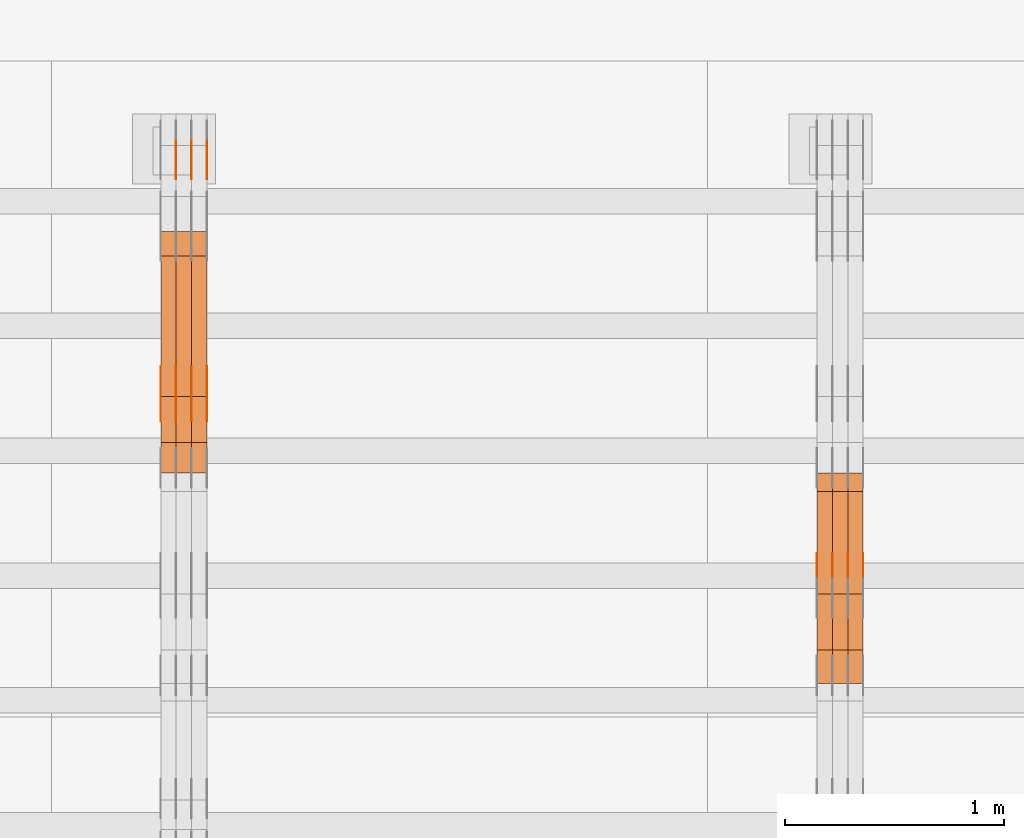
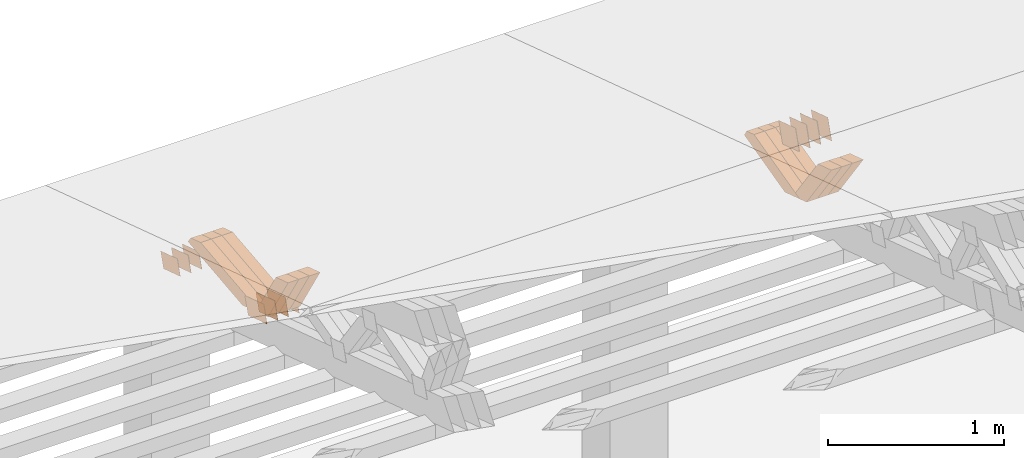
# One storey, part 237 of 385: 28 proxies.
"""IFC2X3 building model written with IfcOpenShell, lengths in millimetres."""

from ifc_helpers import new_model, entity, si_unit, converted_unit, derived_unit, direction, frame, origin, place, context, subcontext, project, spatial, polyline, outline, extrude, source, transform, mapped, material, type_object, type_shapes, element, save


model = new_model("IFC2X3")

# Units and contexts
model_context = context("Model", 3, precision=0.01, world=origin(), true_north=direction((6.12303176911189e-17, 1.0)))
body_context = subcontext(model_context, "Body", "Model", "MODEL_VIEW")
ifc_project = project(units=[si_unit("LENGTHUNIT", "METRE", prefix="MILLI"), si_unit("AREAUNIT", "SQUARE_METRE"), si_unit("VOLUMEUNIT", "CUBIC_METRE"), converted_unit("PLANEANGLEUNIT", "DEGREE", entity("IfcRatioMeasure", 0.0174532925199433), si_unit("PLANEANGLEUNIT", "RADIAN"), dimensions=[0, 0, 0, 0, 0, 0, 0]), si_unit("MASSUNIT", "GRAM", prefix="KILO"), derived_unit("MASSDENSITYUNIT", [(si_unit("MASSUNIT", "GRAM", prefix="KILO"), 1), (si_unit("LENGTHUNIT", "METRE"), -3)]), si_unit("TIMEUNIT", "SECOND"), si_unit("FREQUENCYUNIT", "HERTZ"), si_unit("THERMODYNAMICTEMPERATUREUNIT", "DEGREE_CELSIUS"), derived_unit("THERMALTRANSMITTANCEUNIT", [(si_unit("MASSUNIT", "GRAM", prefix="KILO"), 1), (si_unit("THERMODYNAMICTEMPERATUREUNIT", "KELVIN"), -1), (si_unit("TIMEUNIT", "SECOND"), -3)]), derived_unit("VOLUMETRICFLOWRATEUNIT", [(si_unit("LENGTHUNIT", "METRE"), 3), (si_unit("TIMEUNIT", "SECOND"), -1)]), si_unit("ELECTRICCURRENTUNIT", "AMPERE"), si_unit("ELECTRICVOLTAGEUNIT", "VOLT"), si_unit("POWERUNIT", "WATT"), si_unit("FORCEUNIT", "NEWTON", prefix="KILO"), si_unit("ILLUMINANCEUNIT", "LUX"), si_unit("LUMINOUSFLUXUNIT", "LUMEN"), si_unit("LUMINOUSINTENSITYUNIT", "CANDELA"), derived_unit("USERDEFINED", [(si_unit("MASSUNIT", "GRAM", prefix="KILO"), -1), (si_unit("LENGTHUNIT", "METRE"), -2), (si_unit("TIMEUNIT", "SECOND"), 3), (si_unit("LUMINOUSFLUXUNIT", "LUMEN"), 1)]), derived_unit("LINEARVELOCITYUNIT", [(si_unit("LENGTHUNIT", "METRE"), 1), (si_unit("TIMEUNIT", "SECOND"), -1)]), si_unit("PRESSUREUNIT", "PASCAL"), derived_unit("USERDEFINED", [(si_unit("LENGTHUNIT", "METRE"), -2), (si_unit("MASSUNIT", "GRAM", prefix="KILO"), 1), (si_unit("TIMEUNIT", "SECOND"), -2)])], contexts=[model_context])

# Site, building, storey
site_placement = place(None, origin())
site = spatial("IfcSite", under=ifc_project, at=site_placement, CompositionType="ELEMENT")
building_placement = place(site_placement, origin())
building = spatial("IfcBuilding", under=site, at=building_placement, CompositionType="ELEMENT")
storey_placement = place(building_placement, origin())
storey = spatial("IfcBuildingStorey", under=building, at=storey_placement, Name="Default", CompositionType="ELEMENT", Elevation=0.0)

# Proxies
ifc_material_1 = material(Name="IfcSurfaceStyle #329768")
building_element_proxy_type_1 = type_object("IfcBuildingElementProxyType", PredefinedType="NOTDEFINED", material=ifc_material_1)
shared_shape_1 = source(origin(), body_context, "Body", "SweptSolid", [
    extrude(outline(polyline([(-100.000009625089, -72.0000630699202), (100.000090167682, -72.0000630699202), (100.000009625089, 72.0000630699202), (-100.000090167682, 72.0000630699202), (-100.000009625089, -72.0000630699202)])), frame((100.000090167682, 72.0000630699202, 0.0), z_axis=(0.0, 0.0, 1.0), x_axis=(-1.0, 0.0, 0.0)), (0.0, 0.0, 1.0), 1.3),
])
type_shapes(building_element_proxy_type_1, [shared_shape_1])
proxy_1_placement = place(building_placement, frame((27386.3, 24447.7695802369, 1088.58717039832), z_axis=(-1.0, 0.0, 0.0), x_axis=(0.0, -0.951056516295154, 0.309016994374948)))
element("IfcBuildingElementProxy", 1, at=proxy_1_placement, inside=storey, type_object=building_element_proxy_type_1, material=ifc_material_1, context=body_context, shape_type="MappedRepresentation", body=[
    mapped(shared_shape_1, transform((0.0, 0.0, 0.0), scale=1.0)),
])
ifc_material_2 = material(Name="IfcSurfaceStyle #329711")
building_element_proxy_type_2 = type_object("IfcBuildingElementProxyType", PredefinedType="NOTDEFINED", material=ifc_material_2)
shared_shape_2 = source(origin(), body_context, "Body", "SweptSolid", [
    extrude(outline(polyline([(-100.000009625089, -72.0000630699202), (100.000090167682, -72.0000630699202), (100.000009625089, 72.0000630699202), (-100.000090167682, 72.0000630699202), (-100.000009625089, -72.0000630699202)])), frame((100.000090167682, 72.0000630699202, 0.0), z_axis=(0.0, 0.0, 1.0), x_axis=(-1.0, 0.0, 0.0)), (0.0, 0.0, 1.0), 1.3),
])
type_shapes(building_element_proxy_type_2, [shared_shape_2])
proxy_2_placement = place(building_placement, frame((27315.0, 24447.7695802369, 1088.58717039832), z_axis=(-1.0, 0.0, 0.0), x_axis=(0.0, -0.951056516295154, 0.309016994374948)))
element("IfcBuildingElementProxy", 2, at=proxy_2_placement, inside=storey, type_object=building_element_proxy_type_2, material=ifc_material_2, context=body_context, shape_type="MappedRepresentation", body=[
    mapped(shared_shape_2, transform((0.0, 0.0, 0.0), scale=1.0)),
])
ifc_material_3 = material(Name="IfcSurfaceStyle #329654")
building_element_proxy_type_3 = type_object("IfcBuildingElementProxyType", PredefinedType="NOTDEFINED", material=ifc_material_3)
shared_shape_3 = source(origin(), body_context, "Body", "SweptSolid", [
    extrude(outline(polyline([(-100.000009625089, -72.0000630699202), (100.000090167682, -72.0000630699202), (100.000009625089, 72.0000630699202), (-100.000090167682, 72.0000630699202), (-100.000009625089, -72.0000630699202)])), frame((100.000090167682, 72.0000630699202, 0.0), z_axis=(0.0, 0.0, 1.0), x_axis=(-1.0, 0.0, 0.0)), (0.0, 0.0, 1.0), 1.3),
])
type_shapes(building_element_proxy_type_3, [shared_shape_3])
proxy_3_placement = place(building_placement, frame((27316.3, 24447.7695802369, 1088.58717039832), z_axis=(-1.0, 0.0, 0.0), x_axis=(0.0, -0.951056516295154, 0.309016994374948)))
element("IfcBuildingElementProxy", 3, at=proxy_3_placement, inside=storey, type_object=building_element_proxy_type_3, material=ifc_material_3, context=body_context, shape_type="MappedRepresentation", body=[
    mapped(shared_shape_3, transform((0.0, 0.0, 0.0), scale=1.0)),
])
ifc_material_4 = material(Name="IfcSurfaceStyle #329597")
building_element_proxy_type_4 = type_object("IfcBuildingElementProxyType", PredefinedType="NOTDEFINED", material=ifc_material_4)
shared_shape_4 = source(origin(), body_context, "Body", "SweptSolid", [
    extrude(outline(polyline([(-100.000009625089, -72.0000630699202), (100.000090167682, -72.0000630699202), (100.000009625089, 72.0000630699202), (-100.000090167682, 72.0000630699202), (-100.000009625089, -72.0000630699202)])), frame((100.000090167682, 72.0000630699202, 0.0), z_axis=(0.0, 0.0, 1.0), x_axis=(-1.0, 0.0, 0.0)), (0.0, 0.0, 1.0), 1.29999999999998),
])
type_shapes(building_element_proxy_type_4, [shared_shape_4])
proxy_4_placement = place(building_placement, frame((27245.0, 24447.7695802369, 1088.58717039832), z_axis=(-1.0, 0.0, 0.0), x_axis=(0.0, -0.951056516295154, 0.309016994374948)))
element("IfcBuildingElementProxy", 4, at=proxy_4_placement, inside=storey, type_object=building_element_proxy_type_4, material=ifc_material_4, context=body_context, shape_type="MappedRepresentation", body=[
    mapped(shared_shape_4, transform((0.0, 0.0, 0.0), scale=1.0)),
])
ifc_material_5 = material(Name="IfcSurfaceStyle #329540")
building_element_proxy_type_5 = type_object("IfcBuildingElementProxyType", PredefinedType="NOTDEFINED", material=ifc_material_5)
shared_shape_5 = source(origin(), body_context, "Body", "SweptSolid", [
    extrude(outline(polyline([(-100.000009625089, -72.0000630699202), (100.000090167682, -72.0000630699202), (100.000009625089, 72.0000630699202), (-100.000090167682, 72.0000630699202), (-100.000009625089, -72.0000630699202)])), frame((100.000090167682, 72.0000630699202, 0.0), z_axis=(0.0, 0.0, 1.0), x_axis=(-1.0, 0.0, 0.0)), (0.0, 0.0, 1.0), 1.29999999999998),
])
type_shapes(building_element_proxy_type_5, [shared_shape_5])
proxy_5_placement = place(building_placement, frame((27246.3, 24447.7695802369, 1088.58717039832), z_axis=(-1.0, 0.0, 0.0), x_axis=(0.0, -0.951056516295154, 0.309016994374948)))
element("IfcBuildingElementProxy", 5, at=proxy_5_placement, inside=storey, type_object=building_element_proxy_type_5, material=ifc_material_5, context=body_context, shape_type="MappedRepresentation", body=[
    mapped(shared_shape_5, transform((0.0, 0.0, 0.0), scale=1.0)),
])
ifc_material_6 = material(Name="IfcSurfaceStyle #329483")
building_element_proxy_type_6 = type_object("IfcBuildingElementProxyType", PredefinedType="NOTDEFINED", material=ifc_material_6)
shared_shape_6 = source(origin(), body_context, "Body", "SweptSolid", [
    extrude(outline(polyline([(-100.000009625089, -72.0000630699202), (100.000090167682, -72.0000630699202), (100.000009625089, 72.0000630699202), (-100.000090167682, 72.0000630699202), (-100.000009625089, -72.0000630699202)])), frame((100.000090167682, 72.0000630699202, 0.0), z_axis=(0.0, 0.0, 1.0), x_axis=(-1.0, 0.0, 0.0)), (0.0, 0.0, 1.0), 1.29999999999999),
])
type_shapes(building_element_proxy_type_6, [shared_shape_6])
proxy_6_placement = place(building_placement, frame((27175.0, 24447.7695802369, 1088.58717039832), z_axis=(-1.0, 0.0, 0.0), x_axis=(0.0, -0.951056516295154, 0.309016994374948)))
element("IfcBuildingElementProxy", 6, at=proxy_6_placement, inside=storey, type_object=building_element_proxy_type_6, material=ifc_material_6, context=body_context, shape_type="MappedRepresentation", body=[
    mapped(shared_shape_6, transform((0.0, 0.0, 0.0), scale=1.0)),
])
ifc_material_7 = material(Name="IfcSurfaceStyle #320570")
building_element_proxy_type_7 = type_object("IfcBuildingElementProxyType", Name="T1-W24 320568", PredefinedType="NOTDEFINED", material=ifc_material_7)
shared_shape_7 = source(origin(), body_context, "Body", "SweptSolid", [
    extrude(outline(polyline([(-215.642157779899, -47.4998772343114), (220.829928576248, -47.4998772343114), (202.182343865616, 6.34871490324596e-05), (137.545638852774, 47.4998454907369), (-344.915753514738, 47.4998454907369), (-215.642157779899, -47.4998772343114)])), frame((220.830079609702, 47.500154567531, 0.0), z_axis=(0.0, 0.0, 1.0), x_axis=(-1.0, 0.0, 0.0)), (0.0, 0.0, 1.0), 70.0),
])
type_shapes(building_element_proxy_type_7, [shared_shape_7])
proxy_7_placement = place(building_placement, frame((27385.0, 24227.7045444998, 781.019082122604), z_axis=(-1.0, 0.0, 0.0), x_axis=(0.0, -0.583381854128324, 0.812198012970851)))
element("IfcBuildingElementProxy", 7, at=proxy_7_placement, inside=storey, type_object=building_element_proxy_type_7, material=ifc_material_7, Name="T1-W24", context=body_context, shape_type="MappedRepresentation", body=[
    mapped(shared_shape_7, transform((0.0, 0.0, 0.0), scale=1.0)),
])
ifc_material_8 = material(Name="IfcSurfaceStyle #320504")
building_element_proxy_type_8 = type_object("IfcBuildingElementProxyType", Name="T1-W24 320502", PredefinedType="NOTDEFINED", material=ifc_material_8)
shared_shape_8 = source(origin(), body_context, "Body", "SweptSolid", [
    extrude(outline(polyline([(-215.642157779899, -47.4998772343114), (220.829928576248, -47.4998772343114), (202.182343865616, 6.34871490324596e-05), (137.545638852774, 47.4998454907369), (-344.915753514738, 47.4998454907369), (-215.642157779899, -47.4998772343114)])), frame((220.830079609702, 47.500154567531, 0.0), z_axis=(0.0, 0.0, 1.0), x_axis=(-1.0, 0.0, 0.0)), (0.0, 0.0, 1.0), 70.0),
])
type_shapes(building_element_proxy_type_8, [shared_shape_8])
proxy_8_placement = place(building_placement, frame((27315.0, 24227.7045444998, 781.019082122604), z_axis=(-1.0, 0.0, 0.0), x_axis=(0.0, -0.583381854128324, 0.812198012970851)))
element("IfcBuildingElementProxy", 8, at=proxy_8_placement, inside=storey, type_object=building_element_proxy_type_8, material=ifc_material_8, Name="T1-W24", context=body_context, shape_type="MappedRepresentation", body=[
    mapped(shared_shape_8, transform((0.0, 0.0, 0.0), scale=1.0)),
])
ifc_material_9 = material(Name="IfcSurfaceStyle #320438")
building_element_proxy_type_9 = type_object("IfcBuildingElementProxyType", Name="T1-W24 320436", PredefinedType="NOTDEFINED", material=ifc_material_9)
shared_shape_9 = source(origin(), body_context, "Body", "SweptSolid", [
    extrude(outline(polyline([(-215.642157779899, -47.4998772343114), (220.829928576248, -47.4998772343114), (202.182343865616, 6.34871490324596e-05), (137.545638852774, 47.4998454907369), (-344.915753514738, 47.4998454907369), (-215.642157779899, -47.4998772343114)])), frame((220.830079609702, 47.500154567531, 0.0), z_axis=(0.0, 0.0, 1.0), x_axis=(-1.0, 0.0, 0.0)), (0.0, 0.0, 1.0), 70.0),
])
type_shapes(building_element_proxy_type_9, [shared_shape_9])
proxy_9_placement = place(building_placement, frame((27245.0, 24227.7045444998, 781.019082122604), z_axis=(-1.0, 0.0, 0.0), x_axis=(0.0, -0.583381854128324, 0.812198012970851)))
element("IfcBuildingElementProxy", 9, at=proxy_9_placement, inside=storey, type_object=building_element_proxy_type_9, material=ifc_material_9, Name="T1-W24", context=body_context, shape_type="MappedRepresentation", body=[
    mapped(shared_shape_9, transform((0.0, 0.0, 0.0), scale=1.0)),
])
ifc_material_10 = material(Name="IfcSurfaceStyle #320174")
building_element_proxy_type_10 = type_object("IfcBuildingElementProxyType", Name="T1-W13 320172", PredefinedType="NOTDEFINED", material=ifc_material_10)
shared_shape_10 = source(origin(), body_context, "Body", "SweptSolid", [
    extrude(outline(polyline([(-384.339592151497, -47.5000055308246), (150.996422207105, -47.5000055308247), (226.265349299398, -4.29484466835994e-05), (240.878612116891, 47.500027005048), (-233.800791471897, 47.500027005048), (-384.339592151497, -47.5000055308246)])), frame((240.878612116891, 47.500027005048, 0.0), z_axis=(0.0, 0.0, 1.0), x_axis=(-1.0, 0.0, 0.0)), (0.0, 0.0, 1.0), 70.0),
])
type_shapes(building_element_proxy_type_10, [shared_shape_10])
proxy_10_placement = place(building_placement, frame((27385.0, 24884.765625, 885.749145507813), z_axis=(-1.0, 0.0, 0.0), x_axis=(0.0, -0.969210894563555, -0.246232089418326)))
element("IfcBuildingElementProxy", 10, at=proxy_10_placement, inside=storey, type_object=building_element_proxy_type_10, material=ifc_material_10, Name="T1-W13", context=body_context, shape_type="MappedRepresentation", body=[
    mapped(shared_shape_10, transform((0.0, 0.0, 0.0), scale=1.0)),
])
ifc_material_11 = material(Name="IfcSurfaceStyle #320108")
building_element_proxy_type_11 = type_object("IfcBuildingElementProxyType", Name="T1-W13 320106", PredefinedType="NOTDEFINED", material=ifc_material_11)
shared_shape_11 = source(origin(), body_context, "Body", "SweptSolid", [
    extrude(outline(polyline([(-384.339592151497, -47.5000055308246), (150.996422207105, -47.5000055308247), (226.265349299398, -4.29484466835994e-05), (240.878612116891, 47.500027005048), (-233.800791471897, 47.500027005048), (-384.339592151497, -47.5000055308246)])), frame((240.878612116891, 47.500027005048, 0.0), z_axis=(0.0, 0.0, 1.0), x_axis=(-1.0, 0.0, 0.0)), (0.0, 0.0, 1.0), 70.0),
])
type_shapes(building_element_proxy_type_11, [shared_shape_11])
proxy_11_placement = place(building_placement, frame((27315.0, 24884.765625, 885.749145507813), z_axis=(-1.0, 0.0, 0.0), x_axis=(0.0, -0.969210894563555, -0.246232089418326)))
element("IfcBuildingElementProxy", 11, at=proxy_11_placement, inside=storey, type_object=building_element_proxy_type_11, material=ifc_material_11, Name="T1-W13", context=body_context, shape_type="MappedRepresentation", body=[
    mapped(shared_shape_11, transform((0.0, 0.0, 0.0), scale=1.0)),
])
ifc_material_12 = material(Name="IfcSurfaceStyle #320042")
building_element_proxy_type_12 = type_object("IfcBuildingElementProxyType", Name="T1-W13 320040", PredefinedType="NOTDEFINED", material=ifc_material_12)
shared_shape_12 = source(origin(), body_context, "Body", "SweptSolid", [
    extrude(outline(polyline([(-384.339592151497, -47.5000055308246), (150.996422207105, -47.5000055308247), (226.265349299398, -4.29484466835994e-05), (240.878612116891, 47.500027005048), (-233.800791471897, 47.500027005048), (-384.339592151497, -47.5000055308246)])), frame((240.878612116891, 47.500027005048, 0.0), z_axis=(0.0, 0.0, 1.0), x_axis=(-1.0, 0.0, 0.0)), (0.0, 0.0, 1.0), 70.0),
])
type_shapes(building_element_proxy_type_12, [shared_shape_12])
proxy_12_placement = place(building_placement, frame((27245.0, 24884.765625, 885.749145507813), z_axis=(-1.0, 0.0, 0.0), x_axis=(0.0, -0.969210894563555, -0.246232089418326)))
element("IfcBuildingElementProxy", 12, at=proxy_12_placement, inside=storey, type_object=building_element_proxy_type_12, material=ifc_material_12, Name="T1-W13", context=body_context, shape_type="MappedRepresentation", body=[
    mapped(shared_shape_12, transform((0.0, 0.0, 0.0), scale=1.0)),
])
ifc_material_13 = material(Name="IfcSurfaceStyle #309358")
building_element_proxy_type_13 = type_object("IfcBuildingElementProxyType", PredefinedType="NOTDEFINED", material=ifc_material_13)
shared_shape_13 = source(origin(), body_context, "Body", "SweptSolid", [
    extrude(outline(polyline([(-100.000024997547, -54.0000105875654), (100.000088940899, -54.0000105875654), (99.9999100805868, 54.0000105875654), (-99.9999740239394, 54.0000105875654), (-100.000024997547, -54.0000105875654)])), frame((100.000088940899, 54.0000474633838, 0.0), z_axis=(0.0, 0.0, 1.0), x_axis=(-1.0, 0.0, 0.0)), (0.0, 0.0, 1.0), 1.3),
])
type_shapes(building_element_proxy_type_13, [shared_shape_13])
proxy_13_placement = place(building_placement, frame((24386.3, 26390.6212638563, 73.3227520411355), z_axis=(-1.0, 0.0, 0.0), x_axis=(0.0, -0.951056516295124, 0.309016994375039)))
element("IfcBuildingElementProxy", 13, at=proxy_13_placement, inside=storey, type_object=building_element_proxy_type_13, material=ifc_material_13, context=body_context, shape_type="MappedRepresentation", body=[
    mapped(shared_shape_13, transform((0.0, 0.0, 0.0), scale=1.0)),
])
ifc_material_14 = material(Name="IfcSurfaceStyle #309301")
building_element_proxy_type_14 = type_object("IfcBuildingElementProxyType", PredefinedType="NOTDEFINED", material=ifc_material_14)
shared_shape_14 = source(origin(), body_context, "Body", "SweptSolid", [
    extrude(outline(polyline([(-100.000024997547, -54.0000105875654), (100.000088940899, -54.0000105875654), (99.9999100805868, 54.0000105875654), (-99.9999740239394, 54.0000105875654), (-100.000024997547, -54.0000105875654)])), frame((100.000088940899, 54.0000474633838, 0.0), z_axis=(0.0, 0.0, 1.0), x_axis=(-1.0, 0.0, 0.0)), (0.0, 0.0, 1.0), 1.3),
])
type_shapes(building_element_proxy_type_14, [shared_shape_14])
proxy_14_placement = place(building_placement, frame((24315.0, 26390.6212638563, 73.3227520411355), z_axis=(-1.0, 0.0, 0.0), x_axis=(0.0, -0.951056516295124, 0.309016994375039)))
element("IfcBuildingElementProxy", 14, at=proxy_14_placement, inside=storey, type_object=building_element_proxy_type_14, material=ifc_material_14, context=body_context, shape_type="MappedRepresentation", body=[
    mapped(shared_shape_14, transform((0.0, 0.0, 0.0), scale=1.0)),
])
ifc_material_15 = material(Name="IfcSurfaceStyle #309244")
building_element_proxy_type_15 = type_object("IfcBuildingElementProxyType", PredefinedType="NOTDEFINED", material=ifc_material_15)
shared_shape_15 = source(origin(), body_context, "Body", "SweptSolid", [
    extrude(outline(polyline([(-100.000024997547, -54.0000105875654), (100.000088940899, -54.0000105875654), (99.9999100805868, 54.0000105875654), (-99.9999740239394, 54.0000105875654), (-100.000024997547, -54.0000105875654)])), frame((100.000088940899, 54.0000474633838, 0.0), z_axis=(0.0, 0.0, 1.0), x_axis=(-1.0, 0.0, 0.0)), (0.0, 0.0, 1.0), 1.3),
])
type_shapes(building_element_proxy_type_15, [shared_shape_15])
proxy_15_placement = place(building_placement, frame((24316.3, 26390.6212638563, 73.3227520411355), z_axis=(-1.0, 0.0, 0.0), x_axis=(0.0, -0.951056516295124, 0.309016994375039)))
element("IfcBuildingElementProxy", 15, at=proxy_15_placement, inside=storey, type_object=building_element_proxy_type_15, material=ifc_material_15, context=body_context, shape_type="MappedRepresentation", body=[
    mapped(shared_shape_15, transform((0.0, 0.0, 0.0), scale=1.0)),
])
ifc_material_16 = material(Name="IfcSurfaceStyle #309187")
building_element_proxy_type_16 = type_object("IfcBuildingElementProxyType", PredefinedType="NOTDEFINED", material=ifc_material_16)
shared_shape_16 = source(origin(), body_context, "Body", "SweptSolid", [
    extrude(outline(polyline([(-100.000024997547, -54.0000105875654), (100.000088940899, -54.0000105875654), (99.9999100805868, 54.0000105875654), (-99.9999740239394, 54.0000105875654), (-100.000024997547, -54.0000105875654)])), frame((100.000088940899, 54.0000474633838, 0.0), z_axis=(0.0, 0.0, 1.0), x_axis=(-1.0, 0.0, 0.0)), (0.0, 0.0, 1.0), 1.29999999999998),
])
type_shapes(building_element_proxy_type_16, [shared_shape_16])
proxy_16_placement = place(building_placement, frame((24245.0, 26390.6212638563, 73.3227520411355), z_axis=(-1.0, 0.0, 0.0), x_axis=(0.0, -0.951056516295124, 0.309016994375039)))
element("IfcBuildingElementProxy", 16, at=proxy_16_placement, inside=storey, type_object=building_element_proxy_type_16, material=ifc_material_16, context=body_context, shape_type="MappedRepresentation", body=[
    mapped(shared_shape_16, transform((0.0, 0.0, 0.0), scale=1.0)),
])
ifc_material_17 = material(Name="IfcSurfaceStyle #297388")
building_element_proxy_type_17 = type_object("IfcBuildingElementProxyType", PredefinedType="NOTDEFINED", material=ifc_material_17)
shared_shape_17 = source(origin(), body_context, "Body", "SweptSolid", [
    extrude(outline(polyline([(-112.50003853564, -60.0000121429077), (112.50002982902, -60.0000121429077), (112.500043250865, 60.0000121429077), (-112.500034544245, 60.0000121429077), (-112.50003853564, -60.0000121429077)])), frame((112.500056021398, 60.0000121429077, 0.0), z_axis=(0.0, 0.0, 1.0), x_axis=(-1.0, 0.0, 0.0)), (0.0, 0.0, 1.0), 1.3),
])
type_shapes(building_element_proxy_type_17, [shared_shape_17])
proxy_17_placement = place(building_placement, frame((24386.3, 25310.2182710494, 430.675738123044), z_axis=(-1.0, 0.0, 0.0), x_axis=(0.0, -0.951056516295124, 0.309016994375039)))
element("IfcBuildingElementProxy", 17, at=proxy_17_placement, inside=storey, type_object=building_element_proxy_type_17, material=ifc_material_17, context=body_context, shape_type="MappedRepresentation", body=[
    mapped(shared_shape_17, transform((0.0, 0.0, 0.0), scale=1.0)),
])
ifc_material_18 = material(Name="IfcSurfaceStyle #297331")
building_element_proxy_type_18 = type_object("IfcBuildingElementProxyType", PredefinedType="NOTDEFINED", material=ifc_material_18)
shared_shape_18 = source(origin(), body_context, "Body", "SweptSolid", [
    extrude(outline(polyline([(-112.50003853564, -60.0000121429077), (112.50002982902, -60.0000121429077), (112.500043250865, 60.0000121429077), (-112.500034544245, 60.0000121429077), (-112.50003853564, -60.0000121429077)])), frame((112.500056021398, 60.0000121429077, 0.0), z_axis=(0.0, 0.0, 1.0), x_axis=(-1.0, 0.0, 0.0)), (0.0, 0.0, 1.0), 1.3),
])
type_shapes(building_element_proxy_type_18, [shared_shape_18])
proxy_18_placement = place(building_placement, frame((24315.0, 25310.2182710494, 430.675738123044), z_axis=(-1.0, 0.0, 0.0), x_axis=(0.0, -0.951056516295124, 0.309016994375039)))
element("IfcBuildingElementProxy", 18, at=proxy_18_placement, inside=storey, type_object=building_element_proxy_type_18, material=ifc_material_18, context=body_context, shape_type="MappedRepresentation", body=[
    mapped(shared_shape_18, transform((0.0, 0.0, 0.0), scale=1.0)),
])
ifc_material_19 = material(Name="IfcSurfaceStyle #297274")
building_element_proxy_type_19 = type_object("IfcBuildingElementProxyType", PredefinedType="NOTDEFINED", material=ifc_material_19)
shared_shape_19 = source(origin(), body_context, "Body", "SweptSolid", [
    extrude(outline(polyline([(-112.50003853564, -60.0000121429077), (112.50002982902, -60.0000121429077), (112.500043250865, 60.0000121429077), (-112.500034544245, 60.0000121429077), (-112.50003853564, -60.0000121429077)])), frame((112.500056021398, 60.0000121429077, 0.0), z_axis=(0.0, 0.0, 1.0), x_axis=(-1.0, 0.0, 0.0)), (0.0, 0.0, 1.0), 1.3),
])
type_shapes(building_element_proxy_type_19, [shared_shape_19])
proxy_19_placement = place(building_placement, frame((24316.3, 25310.2182710494, 430.675738123044), z_axis=(-1.0, 0.0, 0.0), x_axis=(0.0, -0.951056516295124, 0.309016994375039)))
element("IfcBuildingElementProxy", 19, at=proxy_19_placement, inside=storey, type_object=building_element_proxy_type_19, material=ifc_material_19, context=body_context, shape_type="MappedRepresentation", body=[
    mapped(shared_shape_19, transform((0.0, 0.0, 0.0), scale=1.0)),
])
ifc_material_20 = material(Name="IfcSurfaceStyle #297217")
building_element_proxy_type_20 = type_object("IfcBuildingElementProxyType", PredefinedType="NOTDEFINED", material=ifc_material_20)
shared_shape_20 = source(origin(), body_context, "Body", "SweptSolid", [
    extrude(outline(polyline([(-112.50003853564, -60.0000121429077), (112.50002982902, -60.0000121429077), (112.500043250865, 60.0000121429077), (-112.500034544245, 60.0000121429077), (-112.50003853564, -60.0000121429077)])), frame((112.500056021398, 60.0000121429077, 0.0), z_axis=(0.0, 0.0, 1.0), x_axis=(-1.0, 0.0, 0.0)), (0.0, 0.0, 1.0), 1.29999999999998),
])
type_shapes(building_element_proxy_type_20, [shared_shape_20])
proxy_20_placement = place(building_placement, frame((24245.0, 25310.2182710494, 430.675738123044), z_axis=(-1.0, 0.0, 0.0), x_axis=(0.0, -0.951056516295124, 0.309016994375039)))
element("IfcBuildingElementProxy", 20, at=proxy_20_placement, inside=storey, type_object=building_element_proxy_type_20, material=ifc_material_20, context=body_context, shape_type="MappedRepresentation", body=[
    mapped(shared_shape_20, transform((0.0, 0.0, 0.0), scale=1.0)),
])
ifc_material_21 = material(Name="IfcSurfaceStyle #297160")
building_element_proxy_type_21 = type_object("IfcBuildingElementProxyType", PredefinedType="NOTDEFINED", material=ifc_material_21)
shared_shape_21 = source(origin(), body_context, "Body", "SweptSolid", [
    extrude(outline(polyline([(-112.50003853564, -60.0000121429077), (112.50002982902, -60.0000121429077), (112.500043250865, 60.0000121429077), (-112.500034544245, 60.0000121429077), (-112.50003853564, -60.0000121429077)])), frame((112.500056021398, 60.0000121429077, 0.0), z_axis=(0.0, 0.0, 1.0), x_axis=(-1.0, 0.0, 0.0)), (0.0, 0.0, 1.0), 1.29999999999998),
])
type_shapes(building_element_proxy_type_21, [shared_shape_21])
proxy_21_placement = place(building_placement, frame((24246.3, 25310.2182710494, 430.675738123044), z_axis=(-1.0, 0.0, 0.0), x_axis=(0.0, -0.951056516295124, 0.309016994375039)))
element("IfcBuildingElementProxy", 21, at=proxy_21_placement, inside=storey, type_object=building_element_proxy_type_21, material=ifc_material_21, context=body_context, shape_type="MappedRepresentation", body=[
    mapped(shared_shape_21, transform((0.0, 0.0, 0.0), scale=1.0)),
])
ifc_material_22 = material(Name="IfcSurfaceStyle #297103")
building_element_proxy_type_22 = type_object("IfcBuildingElementProxyType", PredefinedType="NOTDEFINED", material=ifc_material_22)
shared_shape_22 = source(origin(), body_context, "Body", "SweptSolid", [
    extrude(outline(polyline([(-112.50003853564, -60.0000121429077), (112.50002982902, -60.0000121429077), (112.500043250865, 60.0000121429077), (-112.500034544245, 60.0000121429077), (-112.50003853564, -60.0000121429077)])), frame((112.500056021398, 60.0000121429077, 0.0), z_axis=(0.0, 0.0, 1.0), x_axis=(-1.0, 0.0, 0.0)), (0.0, 0.0, 1.0), 1.29999999999999),
])
type_shapes(building_element_proxy_type_22, [shared_shape_22])
proxy_22_placement = place(building_placement, frame((24175.0, 25310.2182710494, 430.675738123044), z_axis=(-1.0, 0.0, 0.0), x_axis=(0.0, -0.951056516295124, 0.309016994375039)))
element("IfcBuildingElementProxy", 22, at=proxy_22_placement, inside=storey, type_object=building_element_proxy_type_22, material=ifc_material_22, context=body_context, shape_type="MappedRepresentation", body=[
    mapped(shared_shape_22, transform((0.0, 0.0, 0.0), scale=1.0)),
])
ifc_material_23 = material(Name="IfcSurfaceStyle #285346")
building_element_proxy_type_23 = type_object("IfcBuildingElementProxyType", Name="T1-W31 285344", PredefinedType="NOTDEFINED", material=ifc_material_23)
shared_shape_23 = source(origin(), body_context, "Body", "SweptSolid", [
    extrude(outline(polyline([(-201.245318299844, -47.5000121670808), (204.413774229459, -47.5000121670808), (182.034306640891, 5.35692244583164e-05), (126.70380769348, 47.4999853824686), (-311.906570263987, 47.4999853824686), (-201.245318299844, -47.5000121670808)])), frame((204.413774229459, 47.5002684334588, 0.0), z_axis=(0.0, 0.0, 1.0), x_axis=(-1.0, 0.0, 0.0)), (0.0, 0.0, 1.0), 70.0),
])
type_shapes(building_element_proxy_type_23, [shared_shape_23])
proxy_23_placement = place(building_placement, frame((24385.0, 25127.5652647985, 487.27008059185), z_axis=(-1.0, 0.0, 0.0), x_axis=(0.0, -0.520333970303023, 0.853962855953755)))
element("IfcBuildingElementProxy", 23, at=proxy_23_placement, inside=storey, type_object=building_element_proxy_type_23, material=ifc_material_23, Name="T1-W31", context=body_context, shape_type="MappedRepresentation", body=[
    mapped(shared_shape_23, transform((0.0, 0.0, 0.0), scale=1.0)),
])
ifc_material_24 = material(Name="IfcSurfaceStyle #285280")
building_element_proxy_type_24 = type_object("IfcBuildingElementProxyType", Name="T1-W31 285278", PredefinedType="NOTDEFINED", material=ifc_material_24)
shared_shape_24 = source(origin(), body_context, "Body", "SweptSolid", [
    extrude(outline(polyline([(-201.245318299844, -47.5000121670808), (204.413774229459, -47.5000121670808), (182.034306640891, 5.35692244583164e-05), (126.70380769348, 47.4999853824686), (-311.906570263987, 47.4999853824686), (-201.245318299844, -47.5000121670808)])), frame((204.413774229459, 47.5002684334588, 0.0), z_axis=(0.0, 0.0, 1.0), x_axis=(-1.0, 0.0, 0.0)), (0.0, 0.0, 1.0), 70.0),
])
type_shapes(building_element_proxy_type_24, [shared_shape_24])
proxy_24_placement = place(building_placement, frame((24315.0, 25127.5652647985, 487.27008059185), z_axis=(-1.0, 0.0, 0.0), x_axis=(0.0, -0.520333970303023, 0.853962855953755)))
element("IfcBuildingElementProxy", 24, at=proxy_24_placement, inside=storey, type_object=building_element_proxy_type_24, material=ifc_material_24, Name="T1-W31", context=body_context, shape_type="MappedRepresentation", body=[
    mapped(shared_shape_24, transform((0.0, 0.0, 0.0), scale=1.0)),
])
ifc_material_25 = material(Name="IfcSurfaceStyle #285214")
building_element_proxy_type_25 = type_object("IfcBuildingElementProxyType", Name="T1-W31 285212", PredefinedType="NOTDEFINED", material=ifc_material_25)
shared_shape_25 = source(origin(), body_context, "Body", "SweptSolid", [
    extrude(outline(polyline([(-201.245318299844, -47.5000121670808), (204.413774229459, -47.5000121670808), (182.034306640891, 5.35692244583164e-05), (126.70380769348, 47.4999853824686), (-311.906570263987, 47.4999853824686), (-201.245318299844, -47.5000121670808)])), frame((204.413774229459, 47.5002684334588, 0.0), z_axis=(0.0, 0.0, 1.0), x_axis=(-1.0, 0.0, 0.0)), (0.0, 0.0, 1.0), 70.0),
])
type_shapes(building_element_proxy_type_25, [shared_shape_25])
proxy_25_placement = place(building_placement, frame((24245.0, 25127.5652647985, 487.27008059185), z_axis=(-1.0, 0.0, 0.0), x_axis=(0.0, -0.520333970303023, 0.853962855953755)))
element("IfcBuildingElementProxy", 25, at=proxy_25_placement, inside=storey, type_object=building_element_proxy_type_25, material=ifc_material_25, Name="T1-W31", context=body_context, shape_type="MappedRepresentation", body=[
    mapped(shared_shape_25, transform((0.0, 0.0, 0.0), scale=1.0)),
])
ifc_material_26 = material(Name="IfcSurfaceStyle #284950")
building_element_proxy_type_26 = type_object("IfcBuildingElementProxyType", Name="T1-W4 284948", PredefinedType="NOTDEFINED", material=ifc_material_26)
shared_shape_26 = source(origin(), body_context, "Body", "SweptSolid", [
    extrude(outline(polyline([(-510.077325435179, -47.4999981284922), (188.854793418912, -47.4999981284922), (294.906688207675, 1.67015383116809e-05), (324.289382923648, 47.499989777723), (-297.973539115057, 47.4999897777231), (-510.077325435179, -47.4999981284922)])), frame((324.289382923648, 47.5000278316275, 0.0), z_axis=(0.0, 0.0, 1.0), x_axis=(-1.0, 0.0, 0.0)), (0.0, 0.0, 1.0), 70.0),
])
type_shapes(building_element_proxy_type_26, [shared_shape_26])
proxy_26_placement = place(building_placement, frame((24385.0, 25996.2241251556, 525.69905884318), z_axis=(-1.0, 0.0, 0.0), x_axis=(0.0, -0.994287125203057, -0.106738524701444)))
element("IfcBuildingElementProxy", 26, at=proxy_26_placement, inside=storey, type_object=building_element_proxy_type_26, material=ifc_material_26, Name="T1-W4", context=body_context, shape_type="MappedRepresentation", body=[
    mapped(shared_shape_26, transform((0.0, 0.0, 0.0), scale=1.0)),
])
ifc_material_27 = material(Name="IfcSurfaceStyle #284884")
building_element_proxy_type_27 = type_object("IfcBuildingElementProxyType", Name="T1-W4 284882", PredefinedType="NOTDEFINED", material=ifc_material_27)
shared_shape_27 = source(origin(), body_context, "Body", "SweptSolid", [
    extrude(outline(polyline([(-510.077325435179, -47.4999981284922), (188.854793418912, -47.4999981284922), (294.906688207675, 1.67015383116809e-05), (324.289382923648, 47.499989777723), (-297.973539115057, 47.4999897777231), (-510.077325435179, -47.4999981284922)])), frame((324.289382923648, 47.5000278316275, 0.0), z_axis=(0.0, 0.0, 1.0), x_axis=(-1.0, 0.0, 0.0)), (0.0, 0.0, 1.0), 70.0),
])
type_shapes(building_element_proxy_type_27, [shared_shape_27])
proxy_27_placement = place(building_placement, frame((24315.0, 25996.2241251556, 525.69905884318), z_axis=(-1.0, 0.0, 0.0), x_axis=(0.0, -0.994287125203057, -0.106738524701444)))
element("IfcBuildingElementProxy", 27, at=proxy_27_placement, inside=storey, type_object=building_element_proxy_type_27, material=ifc_material_27, Name="T1-W4", context=body_context, shape_type="MappedRepresentation", body=[
    mapped(shared_shape_27, transform((0.0, 0.0, 0.0), scale=1.0)),
])
ifc_material_28 = material(Name="IfcSurfaceStyle #284818")
building_element_proxy_type_28 = type_object("IfcBuildingElementProxyType", Name="T1-W4 284816", PredefinedType="NOTDEFINED", material=ifc_material_28)
shared_shape_28 = source(origin(), body_context, "Body", "SweptSolid", [
    extrude(outline(polyline([(-510.077325435179, -47.4999981284922), (188.854793418912, -47.4999981284922), (294.906688207675, 1.67015383116809e-05), (324.289382923648, 47.499989777723), (-297.973539115057, 47.4999897777231), (-510.077325435179, -47.4999981284922)])), frame((324.289382923648, 47.5000278316275, 0.0), z_axis=(0.0, 0.0, 1.0), x_axis=(-1.0, 0.0, 0.0)), (0.0, 0.0, 1.0), 70.0),
])
type_shapes(building_element_proxy_type_28, [shared_shape_28])
proxy_28_placement = place(building_placement, frame((24245.0, 25996.2241251556, 525.69905884318), z_axis=(-1.0, 0.0, 0.0), x_axis=(0.0, -0.994287125203057, -0.106738524701444)))
element("IfcBuildingElementProxy", 28, at=proxy_28_placement, inside=storey, type_object=building_element_proxy_type_28, material=ifc_material_28, Name="T1-W4", context=body_context, shape_type="MappedRepresentation", body=[
    mapped(shared_shape_28, transform((0.0, 0.0, 0.0), scale=1.0)),
])

save(model, "model.ifc")
